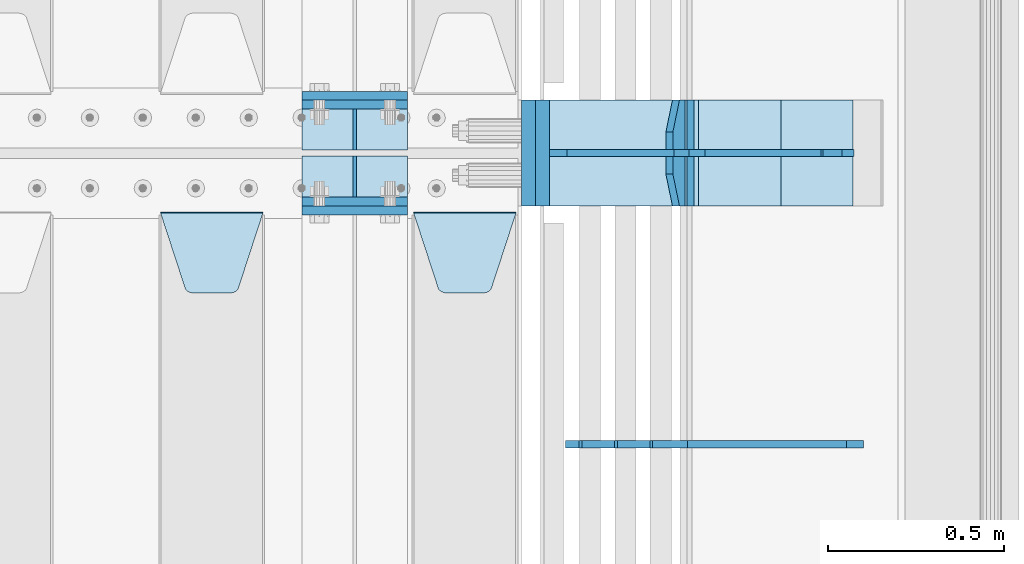
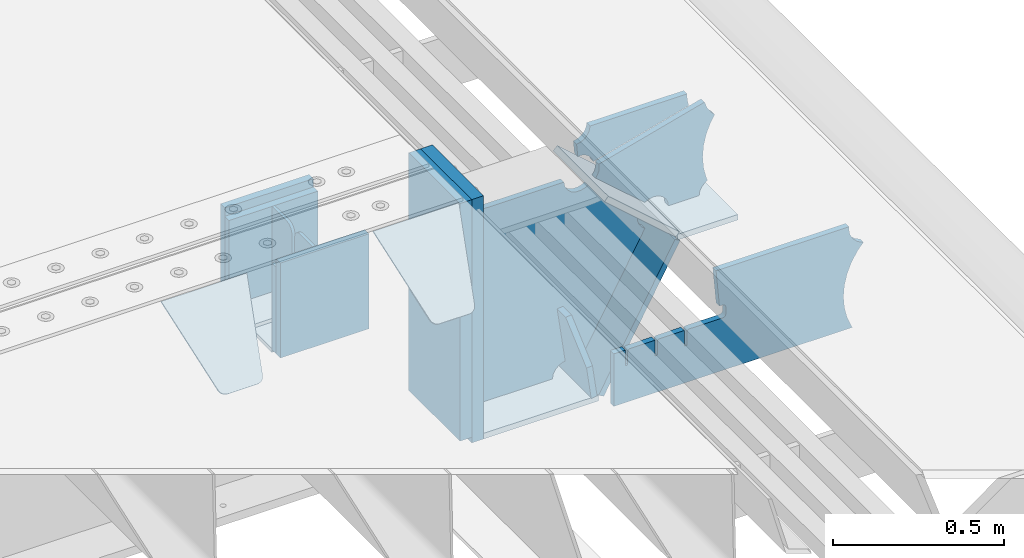
# One storey, part 208 of 240: 21 plates.
"""IFC2X3 building model written with IfcOpenShell, lengths in millimetres."""

from ifc_helpers import new_model, si_unit, frame, origin_with_axes, place, context, subcontext, project, spatial, faceted_brep, material, type_object, element, save


model = new_model("IFC2X3")

# Units and contexts
model_context = context("Model", 3, precision=1e-05, world=origin_with_axes())
body_context = subcontext(model_context, "Body", "Model", "MODEL_VIEW")
ifc_project = project(units=[si_unit("LENGTHUNIT", "METRE", prefix="MILLI"), si_unit("AREAUNIT", "SQUARE_METRE"), si_unit("VOLUMEUNIT", "CUBIC_METRE"), si_unit("MASSUNIT", "GRAM", prefix="KILO"), si_unit("TIMEUNIT", "SECOND"), si_unit("PLANEANGLEUNIT", "RADIAN"), si_unit("SOLIDANGLEUNIT", "STERADIAN"), si_unit("THERMODYNAMICTEMPERATUREUNIT", "DEGREE_CELSIUS"), si_unit("LUMINOUSINTENSITYUNIT", "LUMEN")], contexts=[model_context])

# Site, building, storey
site_placement = place(None, origin_with_axes())
site = spatial("IfcSite", under=ifc_project, at=site_placement, CompositionType="ELEMENT")
building_placement = place(site_placement, origin_with_axes())
building = spatial("IfcBuilding", under=site, at=building_placement, Name="Standard", CompositionType="ELEMENT")
storey_placement = place(building_placement, origin_with_axes())
storey = spatial("IfcBuildingStorey", under=building, at=storey_placement, Name="Undefined", CompositionType="ELEMENT", Elevation=0.0)

# Plates
ifc_material_1 = material(Name="STEEL/S355N")
plate_type_1 = type_object("IfcPlateType", PredefinedType="NOTDEFINED")
for number, where, z_axis, x_axis in (
    (1, (55855.0, 30137.5, -339.999999999995), (0.0, 0.0, 1.0), (1.0, 0.0, 0.0)),
    (2, (55855.0, 29862.5, -339.999999999995), (0.0, 0.0, 1.0), (1.0, 0.0, 0.0)),
):
    element("IfcPlate", number, at=place(storey_placement, frame(where, z_axis=z_axis, x_axis=x_axis)), inside=storey, type_object=plate_type_1, material=ifc_material_1, context=body_context, shape_type="Brep", body=[
        faceted_brep([(0.0, -12.5, 0.0), (0.0, -12.5, 310.0), (0.0, 12.5, 310.0), (0.0, 12.5, 0.0), (300.0, -12.5, 310.0), (300.0, 12.5, 310.0), (300.0, -12.5, 0.0), (300.0, 12.5, 0.0)], [[[0, 1, 2, 3]], [[1, 4, 5, 2]], [[4, 6, 7, 5]], [[6, 0, 3, 7]], [[5, 7, 3, 2]], [[6, 4, 1, 0]]]),
    ])
for number, where, z_axis, x_axis in (
    (3, (55855.0, 30162.5, -340.000000000044), (0.0, 0.0, 1.0), (1.0, 0.0, 0.0)),
    (4, (55855.0, 29837.5, -340.000000000044), (0.0, 0.0, 1.0), (1.0, 0.0, 0.0)),
):
    element("IfcPlate", number, at=place(storey_placement, frame(where, z_axis=z_axis, x_axis=x_axis)), inside=storey, type_object=plate_type_1, material=ifc_material_1, context=body_context, shape_type="Brep", body=[
        faceted_brep([(0.0, -12.5, 0.0), (9.31322574615479e-10, -12.5, 340.0), (9.31322574615479e-10, 12.5, 340.0), (0.0, 12.5, 0.0), (300.0, -12.5, 340.0), (300.0, 12.5, 340.0), (300.0, -12.5, 0.0), (300.0, 12.5, 0.0)], [[[0, 1, 2, 3]], [[1, 4, 5, 2]], [[4, 6, 7, 5]], [[6, 0, 3, 7]], [[5, 7, 3, 2]], [[6, 4, 1, 0]]]),
    ])
plate_type_2 = type_object("IfcPlateType", PredefinedType="NOTDEFINED")
for number, where, z_axis, x_axis in (
    (5, (55855.0, 30008.0, -342.999999999995), (0.0, 1.0, 0.0), (1.0, 0.0, 0.0)),
    (6, (55855.0, 29992.0, -342.999999999995), (0.0, -1.0, 0.0), (1.0, 0.0, 0.0)),
):
    element("IfcPlate", number, at=place(storey_placement, frame(where, z_axis=z_axis, x_axis=x_axis)), inside=storey, type_object=plate_type_2, material=ifc_material_1, context=body_context, shape_type="Brep", body=[
        faceted_brep([(0.0, -7.0, 0.0), (0.0, -7.0, 117.0), (0.0, 7.0, 117.0), (0.0, 7.0, 0.0), (300.0, -7.0, 117.0), (300.0, 7.0, 117.0), (300.0, -7.0, 0.0), (300.0, 7.0, 0.0)], [[[0, 1, 2, 3]], [[1, 4, 5, 2]], [[4, 6, 7, 5]], [[6, 0, 3, 7]], [[5, 7, 3, 2]], [[6, 4, 1, 0]]]),
    ])
plate_type_3 = type_object("IfcPlateType", PredefinedType="NOTDEFINED")
for number, where, z_axis, x_axis in (
    (7, (56005.0, 30008.0, -29.9999999999945), (0.0, 0.0, -1.0), (0.0, 1.0, 0.0)),
    (8, (56005.0, 29992.0, -29.9999999999945), (0.0, 0.0, -1.0), (0.0, -1.0, 0.0)),
):
    element("IfcPlate", number, at=place(storey_placement, frame(where, z_axis=z_axis, x_axis=x_axis)), inside=storey, type_object=plate_type_3, material=ifc_material_1, context=body_context, shape_type="Brep", body=[
        faceted_brep([(0.0, -5.0, 30.0), (0.0, -5.0, 306.0), (0.0, 5.0, 306.0), (0.0, 5.0, 30.0), (117.0, -5.0, 306.0), (117.0, 5.0, 306.0), (117.0, -5.0, 0.0), (117.0, 5.0, 0.0), (30.0, -5.0, 0.0), (30.0, 5.0, 0.0), (24.7905546699913, -5.0, 0.455767409633758), (24.7905546699913, 5.0, 0.455767409633758), (19.7393957002278, -5.0, 1.80922137642275), (19.7393957002278, 5.0, 1.80922137642275), (15.0, -5.0, 4.01923788646684), (15.0, 5.0, 4.01923788646684), (10.7163717094008, -5.0, 7.01866670643066), (10.7163717094008, 5.0, 7.01866670643066), (7.01866670643358, -5.0, 10.7163717094038), (7.01866670643358, 5.0, 10.7163717094038), (4.01923788646673, -5.0, 15.0), (4.01923788646673, 5.0, 15.0), (1.80922137642483, -5.0, 19.7393957002299), (1.80922137642483, 5.0, 19.7393957002299), (0.455767409635882, -5.0, 24.7905546699921), (0.455767409635882, 5.0, 24.7905546699921)], [[[0, 1, 2, 3]], [[1, 4, 5, 2]], [[4, 6, 7, 5]], [[6, 8, 9, 7]], [[8, 10, 11, 9]], [[10, 12, 13, 11]], [[12, 14, 15, 13]], [[14, 16, 17, 15]], [[16, 18, 19, 17]], [[18, 20, 21, 19]], [[20, 22, 23, 21]], [[22, 24, 25, 23]], [[24, 0, 3, 25]], [[5, 7, 9, 11, 13, 15, 17, 19, 21, 23, 25, 3, 2]], [[24, 22, 20, 18, 16, 14, 12, 10, 8, 6, 4, 1, 0]]]),
    ])
plate_type_4 = type_object("IfcPlateType", PredefinedType="NOTDEFINED")
plate_1_placement = place(storey_placement, frame((56172.0, 29831.767766956, -1.76776695296758), z_axis=(0.0, -0.707106781186547, -0.707106781186548), x_axis=(1.0, 0.0, 0.0)))
element("IfcPlate", 9, at=plate_1_placement, inside=storey, type_object=plate_type_4, material=ifc_material_1, context=body_context, shape_type="Brep", body=[
    faceted_brep([(0.0, -2.5, 0.0), (69.345504679477, -2.50000000000364, 300.171731424827), (69.345504679477, 2.49999999999636, 300.171731424827), (0.0, 2.5, 0.0), (70.927406119954, -2.50000000000364, 304.897442415397), (70.927406119954, 2.49999999999636, 304.897442415397), (73.3818627772271, -2.50000000000728, 309.234538108525), (73.3818627772271, 2.49999999999636, 309.234538108529), (76.6187032999587, -2.50000000000728, 313.023683126099), (76.6187032999587, 2.49999999999636, 313.023683126103), (80.5190132705029, -2.50000000000364, 316.125672595368), (80.5190132705029, 2.49999999999636, 316.125672595368), (84.9395038596849, -2.50000000000364, 318.426546230472), (84.9395038596849, 2.49999999999636, 318.426546230472), (89.7177759439219, -2.5, 319.841774983277), (89.7177759439219, 2.49999999999636, 319.841774983273), (94.6782862926484, -2.50000000000364, 320.319366455074), (94.6782862926484, 2.49999999999636, 320.319366455074), (195.321713707352, -2.50000000000364, 320.319366455074), (195.321713707352, 2.49999999999636, 320.319366455074), (200.282224056078, -2.50000000000364, 319.841774983273), (200.282224056078, 2.49999999999636, 319.841774983273), (205.060496140315, -2.50000000000364, 318.426546230472), (205.060496140315, 2.49999999999636, 318.426546230472), (209.480986729497, -2.50000000000364, 316.125672595368), (209.480986729497, 2.49999999999636, 316.125672595368), (213.381296700041, -2.50000000000728, 313.023683126099), (213.381296700041, 2.49999999999272, 313.023683126099), (216.618137222766, -2.50000000000364, 309.234538108522), (216.618137222766, 2.49999999999636, 309.234538108522), (219.072593880039, -2.50000000000364, 304.897442415397), (219.072593880039, 2.49999999999636, 304.897442415397), (220.654495320523, -2.50000000000364, 300.171731424827), (220.654495320523, 2.49999999999636, 300.171731424827), (290.0, -2.50000000000364, -3.63797880709171e-12), (290.0, 2.49999999999636, -3.63797880709171e-12)], [[[0, 1, 2, 3]], [[1, 4, 5, 2]], [[4, 6, 7, 5]], [[6, 8, 9, 7]], [[8, 10, 11, 9]], [[10, 12, 13, 11]], [[12, 14, 15, 13]], [[14, 16, 17, 15]], [[16, 18, 19, 17]], [[18, 20, 21, 19]], [[20, 22, 23, 21]], [[22, 24, 25, 23]], [[24, 26, 27, 25]], [[26, 28, 29, 27]], [[28, 30, 31, 29]], [[30, 32, 33, 31]], [[32, 34, 35, 33]], [[34, 0, 3, 35]], [[5, 7, 9, 11, 13, 15, 17, 19, 21, 23, 25, 27, 29, 31, 33, 35, 3, 2]], [[34, 32, 30, 28, 26, 24, 22, 20, 18, 16, 14, 12, 10, 8, 6, 4, 1, 0]]]),
])
plate_2_placement = place(storey_placement, frame((55455.0, 29831.767766956, -1.76776695296758), z_axis=(0.0, -0.707106781186547, -0.707106781186548), x_axis=(1.0, 0.0, 0.0)))
element("IfcPlate", 10, at=plate_2_placement, inside=storey, type_object=plate_type_4, material=ifc_material_1, context=body_context, shape_type="Brep", body=[
    faceted_brep([(0.0, -2.5, 0.0), (69.345504679477, -2.50000000000364, 300.171731424827), (69.345504679477, 2.49999999999636, 300.171731424827), (0.0, 2.5, 0.0), (70.927406119954, -2.50000000000364, 304.897442415397), (70.927406119954, 2.49999999999636, 304.897442415397), (73.3818627772271, -2.50000000000728, 309.234538108525), (73.3818627772271, 2.49999999999636, 309.234538108529), (76.6187032999587, -2.50000000000728, 313.023683126099), (76.6187032999587, 2.49999999999636, 313.023683126103), (80.5190132705029, -2.50000000000364, 316.125672595368), (80.5190132705029, 2.49999999999636, 316.125672595368), (84.9395038596849, -2.50000000000364, 318.426546230472), (84.9395038596849, 2.49999999999636, 318.426546230472), (89.7177759439219, -2.5, 319.841774983277), (89.7177759439219, 2.49999999999636, 319.841774983273), (94.6782862926484, -2.50000000000364, 320.319366455074), (94.6782862926484, 2.49999999999636, 320.319366455074), (195.321713707352, -2.50000000000364, 320.319366455074), (195.321713707352, 2.49999999999636, 320.319366455074), (200.282224056078, -2.50000000000364, 319.841774983273), (200.282224056078, 2.49999999999636, 319.841774983273), (205.060496140315, -2.50000000000364, 318.426546230472), (205.060496140315, 2.49999999999636, 318.426546230472), (209.480986729497, -2.50000000000364, 316.125672595368), (209.480986729497, 2.49999999999636, 316.125672595368), (213.381296700041, -2.50000000000728, 313.023683126099), (213.381296700041, 2.49999999999272, 313.023683126099), (216.618137222766, -2.50000000000364, 309.234538108522), (216.618137222766, 2.49999999999636, 309.234538108522), (219.072593880039, -2.50000000000364, 304.897442415397), (219.072593880039, 2.49999999999636, 304.897442415397), (220.654495320523, -2.50000000000364, 300.171731424827), (220.654495320523, 2.49999999999636, 300.171731424827), (290.0, -2.50000000000364, -3.63797880709171e-12), (290.0, 2.49999999999636, -3.63797880709171e-12)], [[[0, 1, 2, 3]], [[1, 4, 5, 2]], [[4, 6, 7, 5]], [[6, 8, 9, 7]], [[8, 10, 11, 9]], [[10, 12, 13, 11]], [[12, 14, 15, 13]], [[14, 16, 17, 15]], [[16, 18, 19, 17]], [[18, 20, 21, 19]], [[20, 22, 23, 21]], [[22, 24, 25, 23]], [[24, 26, 27, 25]], [[26, 28, 29, 27]], [[28, 30, 31, 29]], [[30, 32, 33, 31]], [[32, 34, 35, 33]], [[34, 0, 3, 35]], [[5, 7, 9, 11, 13, 15, 17, 19, 21, 23, 25, 27, 29, 31, 33, 35, 3, 2]], [[34, 32, 30, 28, 26, 24, 22, 20, 18, 16, 14, 12, 10, 8, 6, 4, 1, 0]]]),
])
plate_type_5 = type_object("IfcPlateType", PredefinedType="NOTDEFINED")
plate_3_placement = place(storey_placement, frame((56931.0775331947, 30150.0000000017, -871.412303810021), z_axis=(0.0, -1.0, 0.0), x_axis=(-0.137902988002476, 0.0, 0.990445741017643)))
element("IfcPlate", 11, at=plate_3_placement, inside=storey, type_object=plate_type_5, material=ifc_material_1, context=body_context, shape_type="Brep", body=[
    faceted_brep([(0.0, -10.0, 0.0), (-1.98269844986498e-10, -10.0, 300.0), (-1.98269844986498e-10, 10.0, 300.0), (0.0, 10.0, 0.0), (115.0, -10.0, 300.0), (115.0, 10.0, 300.0), (250.0, -10.0, 210.0), (250.0, 10.0, 210.0), (250.0, -10.0, 90.0), (250.0, 10.0, 90.0), (115.0, -10.0, -1.09139364212751e-10), (115.0, 10.0, -1.09139364212751e-10)], [[[0, 1, 2, 3]], [[1, 4, 5, 2]], [[4, 6, 7, 5]], [[6, 8, 9, 7]], [[8, 10, 11, 9]], [[10, 0, 3, 11]], [[5, 7, 9, 11, 3, 2]], [[10, 8, 6, 4, 1, 0]]]),
])
plate_type_6 = type_object("IfcPlateType", PredefinedType="NOTDEFINED")
plate_4_placement = place(storey_placement, frame((56959.9988298914, 30000.0000000001, -179.999999999866), z_axis=(0.0, 0.0, -1.0), x_axis=(-1.0, 0.0, 0.0)))
element("IfcPlate", 12, at=plate_4_placement, inside=storey, type_object=plate_type_6, material=ifc_material_1, context=body_context, shape_type="Brep", body=[
    faceted_brep([(46.0258547361809, 10.0, 641.078828352491), (73.3015011075258, 10.0000000000146, 445.179898435806), (73.3015011075258, -9.99999999998545, 445.179898435806), (46.0258547361809, -10.0, 641.078828352491), (53.4925862871751, 10.0000000000146, 442.421838675757), (53.4925862871751, -9.99999999998545, 442.421838675757), (25.782050112437, 10.0, 641.444230671302), (25.782050112437, -10.0, 641.444230671302), (54.6652503111691, 10.0, 642.447174185377), (54.6652503111691, -10.0, 642.447174185377), (68.6036632070463, -10.0, 649.549150281387), (68.6036632070463, 10.0, 649.549150281387), (79.6652503111691, -10.0, 660.610737385511), (79.6652503111691, 10.0, 660.610737385511), (86.7672264071807, -10.0, 674.549150281387), (86.7672264071807, 10.0, 674.549150281387), (89.2144005924201, -10.0, 690.0), (89.2144005924201, 10.0, 690.0), (353.0, -10.0, 690.0), (353.0, 10.0, 690.0), (355.447174185239, -10.0, 674.549150281253), (355.447174185239, 10.0, 674.549150281253), (362.549150281251, -10.0, 660.610737385376), (362.549150281251, 10.0, 660.610737385376), (373.610737385374, -10.0, 649.549150281253), (373.610737385374, 10.0, 649.549150281253), (387.549150281251, -10.0, 642.447174185242), (387.549150281251, 10.0, 642.447174185242), (403.0, -10.0, 640.0), (403.0, 10.0, 640.0), (403.0, -10.0, 50.0), (403.0, 10.0, 50.0), (387.549150281251, -10.0, 47.5528258147577), (387.549150281251, 10.0, 47.5528258147577), (373.610737385374, -10.0, 40.4508497187474), (373.610737385374, 10.0, 40.4508497187474), (362.549150281251, -10.0, 29.3892626146236), (362.549150281251, 10.0, 29.3892626146236), (355.447174185239, -10.0, 15.4508497187474), (355.447174185239, 10.0, 15.4508497187474), (353.0, -10.0, 0.0), (353.0, 10.0, 0.0), (50.0, -10.0, 0.0), (50.0, 10.0, 0.0), (47.0349915316328, -10.0, 16.9620037619133), (47.0349915316328, 10.0, 16.9620037619133), (38.4916171352306, -10.0, 31.9123081320451), (38.4916171352306, 10.0, 31.9123081320451), (25.3831239081483, -10.0, 43.0778019479116), (25.3831239081483, 10.0, 43.0778019479116), (9.26418358741648, -10.0, 49.1342538608113), (9.26418358741648, 10.0, 49.1342538608113), (-7.95349204488593, -10.0, 49.363366622344), (-7.95349204488593, 10.0, 49.363366622344), (-24.2278808265401, -10.0, 43.7379673813837), (-24.2278808265401, 10.0, 43.7379673813837), (-37.6288347353475, -10.0, 32.9252303934259), (-37.6288347353475, 10.0, 32.9252303934259), (-210.371165264653, -10.0, 184.074769606574), (-210.371165264653, 10.0, 184.074769606574), (-202.382363280565, -10.0, 196.529747922069), (-202.382363280565, 10.0, 196.529747922069), (-198.388707244048, -10.0, 210.777489969227), (-198.388707244048, 10.0, 210.777489969227), (-198.73995746443, -10.0, 225.570193077959), (-198.73995746443, 10.0, 225.570193077959), (-203.40535180681, -10.0, 239.612327446012), (-203.40535180681, 10.0, 239.612327446012), (-211.976299808361, -10.0, 251.674097313455), (-211.976299808361, 10.0, 251.674097313455), (-223.702166612966, -10.0, 260.699145216992), (-223.702166612966, 10.0, 260.699145216992), (-9.29783338703419, -10.0, 646.300854783008), (-9.29783338703419, 10.0, 646.300854783008), (6.98069453598146, -10.0, 640.647282345602), (6.98069453598146, 10.0, 640.647282345602), (24.2117663163663, -10.0, 640.855891896051), (24.2117663163663, 10.0, 640.855891896051)], [[[0, 1, 2, 3]], [[4, 5, 2, 1]], [[6, 7, 5, 4]], [[8, 9, 10, 11]], [[11, 10, 12, 13]], [[13, 12, 14, 15]], [[15, 14, 16, 17]], [[18, 19, 17, 16]], [[18, 20, 21, 19]], [[20, 22, 23, 21]], [[22, 24, 25, 23]], [[24, 26, 27, 25]], [[26, 28, 29, 27]], [[28, 30, 31, 29]], [[30, 32, 33, 31]], [[32, 34, 35, 33]], [[34, 36, 37, 35]], [[36, 38, 39, 37]], [[38, 40, 41, 39]], [[40, 42, 43, 41]], [[42, 44, 45, 43]], [[44, 46, 47, 45]], [[46, 48, 49, 47]], [[48, 50, 51, 49]], [[50, 52, 53, 51]], [[52, 54, 55, 53]], [[54, 56, 57, 55]], [[56, 58, 59, 57]], [[58, 60, 61, 59]], [[60, 62, 63, 61]], [[62, 64, 65, 63]], [[64, 66, 67, 65]], [[66, 68, 69, 67]], [[68, 70, 71, 69]], [[70, 72, 73, 71]], [[72, 74, 75, 73]], [[74, 76, 77, 75]], [[1, 0, 8, 11, 13, 15, 17, 19, 21, 23, 25, 27, 29, 31, 33, 35, 37, 39, 41, 43, 45, 47, 49, 51, 53, 55, 57, 59, 61, 63, 65, 67, 69, 71, 73, 75, 77, 6, 4]], [[9, 8, 0, 3]], [[76, 74, 72, 70, 68, 66, 64, 62, 60, 58, 56, 54, 52, 50, 48, 46, 44, 42, 40, 38, 36, 34, 32, 30, 28, 26, 24, 22, 20, 18, 16, 14, 12, 10, 9, 3, 2, 5, 7]], [[77, 76, 7, 6]]]),
])
plate_type_7 = type_object("IfcPlateType", PredefinedType="NOTDEFINED")
plate_5_placement = place(storey_placement, frame((57500.9988502513, 29999.9999999993, -28.9999913318487), z_axis=(0.260769276985653, 0.0, -0.965401151946889), x_axis=(-0.965401151946889, 0.0, -0.260769276985654)))
element("IfcPlate", 13, at=plate_5_placement, inside=storey, type_object=plate_type_7, material=ifc_material_1, context=body_context, shape_type="Brep", body=[
    faceted_brep([(183.436474692309, 10.0, 275.852500330424), (184.91838860904, 10.0, 264.41784353133), (184.91838860904, -10.0, 264.41784353133), (183.436474692309, -10.0, 275.852500330424), (183.794583267605, 10.0, 224.576469334612), (183.794583267605, -10.0, 224.576469334612), (176.45204977582, 10.0, 185.401410454628), (176.45204977582, -10.0, 185.401410454628), (163.071585676764, 10.0, 147.857286855562), (163.071585676764, -10.0, 147.857286855562), (143.982662403731, 10.0, 112.868559462233), (143.982662403731, -10.0, 112.868559462233), (119.655312600233, 10.0, 81.2967668639885), (119.655312600233, -10.0, 81.2967668639885), (100.960891712748, 10.0, 63.6280409830943), (100.960891712748, -10.0, 63.6280409830943), (194.486836975891, -10.0, 278.751956446691), (207.178624553366, -10.0, 286.650994937518), (207.178624553366, 10.0, 286.650994937518), (194.486836975891, 10.0, 278.751956446691), (216.968013469435, -10.0, 297.948965801399), (216.968013469435, 10.0, 297.948965801399), (222.979925232852, -10.0, 311.635937633771), (222.979925232852, 10.0, 311.635937633771), (323.381647032758, -10.0, 284.515917834986), (323.381647032758, 10.0, 284.515917834986), (321.720617177329, -10.0, 268.853198956864), (321.720617177329, 10.0, 268.853198956864), (325.014344481133, -10.0, 253.450889283185), (325.014344481133, 10.0, 253.450889283185), (332.935986082477, -10.0, 239.837389469556), (332.935986082477, 10.0, 239.837389469556), (344.699462330085, -10.0, 229.363593146938), (344.699462330085, 10.0, 229.363593146938), (359.1374609708, -10.0, 223.068835162203), (359.1374609708, 10.0, 223.068835162203), (374.817271777676, -10.0, 221.577756392893), (374.817271777676, 10.0, 221.577756392893), (390.182952880852, -10.0, 225.03833007813), (390.182952880852, 10.0, 225.03833007813), (512.909060513019, -10.0, 41.5599003357038), (512.909060513019, 10.0, 41.5599003357038), (503.648024844573, -10.0, 33.564366674771), (503.648024844573, 10.0, 33.564366674771), (496.6060645697, -10.0, 23.5590612990018), (496.6060645697, 10.0, 23.5590612990018), (492.204839143924, -10.0, 12.1430832451115), (492.204839143924, 10.0, 12.1430832451115), (490.707885742188, -10.0, 3.8198777474463e-10), (490.707885742188, 10.0, 3.8198777474463e-10), (119.999999999993, -10.0, 9.64064383879304e-11), (119.999999999993, 10.0, 9.64064383879304e-11), (117.226254779103, -10.0, 25.6516118492182), (117.226254779103, 10.0, 25.6516118492182), (109.033246825653, -10.0, 50.1173731021008), (109.033246825653, 10.0, 50.1173731021008)], [[[0, 1, 2, 3]], [[4, 5, 2, 1]], [[6, 7, 5, 4]], [[8, 9, 7, 6]], [[10, 11, 9, 8]], [[12, 13, 11, 10]], [[14, 15, 13, 12]], [[16, 17, 18, 19]], [[17, 20, 21, 18]], [[20, 22, 23, 21]], [[22, 24, 25, 23]], [[24, 26, 27, 25]], [[26, 28, 29, 27]], [[28, 30, 31, 29]], [[30, 32, 33, 31]], [[32, 34, 35, 33]], [[34, 36, 37, 35]], [[36, 38, 39, 37]], [[38, 40, 41, 39]], [[40, 42, 43, 41]], [[42, 44, 45, 43]], [[44, 46, 47, 45]], [[46, 48, 49, 47]], [[48, 50, 51, 49]], [[50, 52, 53, 51]], [[52, 54, 55, 53]], [[10, 8, 6, 4, 1, 0, 19, 18, 21, 23, 25, 27, 29, 31, 33, 35, 37, 39, 41, 43, 45, 47, 49, 51, 53, 55, 14, 12]], [[16, 19, 0, 3]], [[54, 52, 50, 48, 46, 44, 42, 40, 38, 36, 34, 32, 30, 28, 26, 24, 22, 20, 17, 16, 3, 2, 5, 7, 9, 11, 13, 15]], [[55, 54, 15, 14]]]),
])
plate_type_8 = type_object("IfcPlateType", PredefinedType="NOTDEFINED")
plate_6_placement = place(storey_placement, frame((56972.2260590443, 30149.9999999993, -177.219372761326), z_axis=(0.752414935148685, 0.0, -0.658689430130164), x_axis=(0.0, -1.0, 0.0)))
element("IfcPlate", 14, at=plate_6_placement, inside=storey, type_object=plate_type_8, material=ifc_material_1, context=body_context, shape_type="Brep", body=[
    faceted_brep([(0.0, -10.0, 0.0), (1.09139364212751e-10, -10.0000000000073, 319.999999999993), (1.09139364212751e-10, 10.0, 319.999999999993), (0.0, 10.0, 0.0), (300.0, -10.0000000000073, 319.999999999993), (300.0, 10.0, 319.999999999993), (300.0, -10.0, 5.82076609134674e-11), (300.0, 10.0, 5.82076609134674e-11)], [[[0, 1, 2, 3]], [[1, 4, 5, 2]], [[4, 6, 7, 5]], [[6, 0, 3, 7]], [[5, 7, 3, 2]], [[6, 4, 1, 0]]]),
])
plate_7_placement = place(storey_placement, frame((57213.0007288109, 30150.0000000001, -408.004820491625), z_axis=(-0.484064236150485, 0.0, -0.875032465272031), x_axis=(0.0, -1.0, 0.0)))
element("IfcPlate", 15, at=plate_7_placement, inside=storey, type_object=plate_type_8, material=ifc_material_1, context=body_context, shape_type="Brep", body=[
    faceted_brep([(0.0, -10.0, 0.0), (3.86513420380652e-07, -10.0, 533.528442382813), (3.86513420380652e-07, 9.99999999999272, 533.528442382809), (0.0, 10.0, 0.0), (300.003295898438, -10.0000000000073, 533.549133300778), (300.003295898438, 10.0, 533.549133300781), (300.0, -10.0, 5.82076609134674e-11), (300.0, 10.0, 5.82076609134674e-11)], [[[0, 1, 2, 3]], [[1, 4, 5, 2]], [[4, 6, 7, 5]], [[6, 0, 3, 7]], [[5, 7, 3, 2]], [[6, 4, 1, 0]]]),
])
plate_8_placement = place(storey_placement, frame((56556.9988298914, 30150.0000000001, -879.999999999866), z_axis=(0.0, -1.0, 0.0), x_axis=(1.0, 0.0, 0.0)))
element("IfcPlate", 16, at=plate_8_placement, inside=storey, type_object=plate_type_8, material=ifc_material_1, context=body_context, shape_type="Brep", body=[
    faceted_brep([(0.0, -10.0, 0.0), (-1.98269844986498e-10, -10.0, 300.0), (-1.98269844986498e-10, 10.0, 300.0), (0.0, 10.0, 0.0), (389.0, -10.0, 300.0), (389.0, 10.0, 300.0), (389.0, -10.0, 0.0), (389.0, 10.0, 0.0)], [[[0, 1, 2, 3]], [[1, 4, 5, 2]], [[4, 6, 7, 5]], [[6, 0, 3, 7]], [[5, 7, 3, 2]], [[6, 4, 1, 0]]]),
])
plate_type_9 = type_object("IfcPlateType", PredefinedType="NOTDEFINED")
plate_9_placement = place(storey_placement, frame((57416.9988298914, 30149.9999999993, -397.999999999763), z_axis=(-1.0, 0.0, 0.0), x_axis=(0.0, -1.0, 0.0)))
element("IfcPlate", 17, at=plate_9_placement, inside=storey, type_object=plate_type_9, material=ifc_material_1, context=body_context, shape_type="Brep", body=[
    faceted_brep([(0.0, -10.0, 0.0), (4.65661287307739e-10, -10.0, 204.0), (4.65661287307739e-10, 10.0, 204.0), (0.0, 10.0, 0.0), (300.0, -10.0, 204.0), (300.0, 10.0, 204.0), (300.0, -10.0, 5.82076609134674e-11), (300.0, 10.0, 5.82076609134674e-11)], [[[0, 1, 2, 3]], [[1, 4, 5, 2]], [[4, 6, 7, 5]], [[6, 0, 3, 7]], [[5, 7, 3, 2]], [[6, 4, 1, 0]]]),
])
ifc_material_2 = material()
plate_type_10 = type_object("IfcPlateType", PredefinedType="NOTDEFINED")
plate_10_placement = place(storey_placement, frame((56536.9988298907, 30150.0, -889.999999999995), z_axis=(0.0, 0.0, 1.0), x_axis=(0.0, -1.0, 0.0)))
element("IfcPlate", 18, at=plate_10_placement, inside=storey, type_object=plate_type_10, material=ifc_material_2, context=body_context, shape_type="Brep", body=[
    faceted_brep([(0.0, -20.0, 0.0), (0.0, -20.0, 870.0), (0.0, 20.0, 870.0), (0.0, 20.0, 0.0), (300.0, -20.0, 870.0), (300.0, 20.0, 870.0), (300.0, -20.0, -1.81898940354586e-12), (300.0, 20.0, -1.81898940354586e-12)], [[[0, 1, 2, 3]], [[1, 4, 5, 2]], [[4, 6, 7, 5]], [[6, 0, 3, 7]], [[5, 7, 3, 2]], [[6, 4, 1, 0]]]),
])
plate_11_placement = place(storey_placement, frame((56497.0, 30150.0, -870.0), z_axis=(0.0, 0.0, 1.0), x_axis=(0.0, -1.0, 0.0)))
element("IfcPlate", 19, at=plate_11_placement, inside=storey, type_object=plate_type_10, material=ifc_material_2, context=body_context, shape_type="Brep", body=[
    faceted_brep([(0.0, -20.0, 0.0), (0.0, -20.0, 850.0), (0.0, 20.0, 850.0), (0.0, 20.0, 0.0), (300.0, -20.0, 850.0), (300.0, 20.0, 850.0), (300.0, -20.0, -1.81898940354586e-12), (300.0, 20.0, -1.81898940354586e-12)], [[[0, 1, 2, 3]], [[1, 4, 5, 2]], [[4, 6, 7, 5]], [[6, 0, 3, 7]], [[5, 7, 3, 2]], [[6, 4, 1, 0]]]),
])
plate_type_11 = type_object("IfcPlateType", PredefinedType="NOTDEFINED")
plate_12_placement = place(storey_placement, frame((57495.9988298907, 30000.0, -9.99999999999716), z_axis=(0.0, 0.0, -1.0), x_axis=(-1.0, 0.0, 0.0)))
element("IfcPlate", 20, at=plate_12_placement, inside=storey, type_object=plate_type_11, material=ifc_material_1, context=body_context, shape_type="Brep", body=[
    faceted_brep([(164.157641141064, -10.0, 44.1844865875018), (486.71834084086, -10.0, 131.004562768382), (486.71834084086, 10.0, 131.004562768382), (164.157641141064, 10.0, 44.1844865875018), (492.179177700767, -10.0, 118.185717565315), (492.179177700767, 10.0, 118.185717565315), (500.965368826706, -10.0, 107.371542744776), (500.965368826706, 10.0, 107.371542744776), (512.394601349042, -10.0, 99.4018391429503), (512.394601349042, 10.0, 99.4018391429503), (525.579310641864, -10.0, 94.8955133209048), (525.579310641864, 10.0, 94.8955133209048), (539.495606295335, -10.0, 94.2025148824028), (539.495606295335, 10.0, 94.2025148824028), (543.504393704665, -10.0, 49.7974851175972), (543.504393704665, 10.0, 49.7974851175972), (529.167086307512, -10.0, 46.3176139481669), (529.167086307512, 10.0, 46.3176139481669), (516.469507120331, -10.0, 38.8049999196639), (516.469507120331, 10.0, 38.8049999196639), (506.517198234542, -10.0, 27.9137449599276), (506.517198234542, 10.0, 27.9137449599276), (500.17667886756, -10.0, 14.592119649441), (500.17667886756, 10.0, 14.592119649441), (498.0, -10.0, 0.0), (498.0, 10.0, 0.0), (170.0, -10.0, 0.0), (170.0, 10.0, 0.0), (169.632873911985, -10.0, 11.1663820622718), (169.632873911985, 10.0, 11.1663820622718), (168.533081313406, -10.0, 22.2845350637931), (168.533081313406, 10.0, 22.2845350637931), (166.705372351957, -10.0, 33.3064382514178), (166.705372351957, 10.0, 33.3064382514178)], [[[0, 1, 2, 3]], [[1, 4, 5, 2]], [[4, 6, 7, 5]], [[6, 8, 9, 7]], [[8, 10, 11, 9]], [[10, 12, 13, 11]], [[12, 14, 15, 13]], [[14, 16, 17, 15]], [[16, 18, 19, 17]], [[18, 20, 21, 19]], [[20, 22, 23, 21]], [[22, 24, 25, 23]], [[24, 26, 27, 25]], [[26, 28, 29, 27]], [[28, 30, 31, 29]], [[30, 32, 33, 31]], [[32, 0, 3, 33]], [[5, 7, 9, 11, 13, 15, 17, 19, 21, 23, 25, 27, 29, 31, 33, 3, 2]], [[32, 30, 28, 26, 24, 22, 20, 18, 16, 14, 12, 10, 8, 6, 4, 1, 0]]]),
])
plate_type_12 = type_object("IfcPlateType", PredefinedType="NOTDEFINED")
plate_13_placement = place(storey_placement, frame((57442.9182339676, 29174.9992828369, -374.002067436517), z_axis=(0.0, 0.0, 1.0), x_axis=(-1.0, 0.0, 0.0)))
element("IfcPlate", 21, at=plate_13_placement, inside=storey, type_object=plate_type_12, material=ifc_material_1, context=body_context, shape_type="Brep", body=[
    faceted_brep([(801.919404066546, -10.0, 188.0), (801.919404066546, 10.0, 188.0), (801.919404066546, 10.0, 132.002067436952), (801.919404066546, -10.0, 132.002067436952), (793.919404066546, 10.0, 132.002067436952), (793.919404066546, -10.0, 132.002067436952), (793.919404066546, 10.0, 180.002067436952), (793.919404066546, -10.0, 180.002067436952), (793.52785619691, 10.0, 182.474203391951), (793.52785619691, -10.0, 182.474203391951), (792.391540021548, 10.0, 184.704349455291), (792.391540021548, -10.0, 184.704349455291), (790.621686084887, 10.0, 186.474203391951), (790.621686084887, -10.0, 186.474203391951), (788.391540021548, 10.0, 187.610519567313), (788.391540021548, -10.0, 187.610519567313), (785.919404066546, -10.0, 188.002067436952), (785.919404066546, 10.0, 188.0), (841.0, -10.0, 188.0), (841.0, -10.0, 0.0), (841.0, 10.0, 0.0), (841.0, 10.0, 188.0), (33.3619566735943, -10.0, 0.0), (33.3619566735943, 10.0, 0.0), (36.2350612208102, -10.0, 4.68848050267013), (36.2350612208102, 10.0, 4.68848050267013), (51.4877592159319, -10.0, 41.5117508652784), (51.4877592159319, 10.0, 41.5117508652784), (60.7922425881334, -10.0, 80.2677133162964), (60.7922425881334, 10.0, 80.2677133162964), (63.9194040769653, -10.0, 120.002067436515), (63.9194040769653, 10.0, 120.002067436515), (60.7922425881334, -10.0, 159.736421556734), (60.7922425881334, 10.0, 159.736421556734), (51.4877592159319, -10.0, 198.492384007752), (51.4877592159319, 10.0, 198.492384007752), (36.2350612208102, -10.0, 235.31565437036), (36.2350612208102, 10.0, 235.31565437036), (15.4097206482038, -10.0, 269.299521518803), (15.4097206482038, 10.0, 269.299521518803), (-3.35474438100209, -10.0, 291.269887256574), (-3.35474438100209, 10.0, 291.269887256574), (-2.36881039375294, -10.0000000000036, 291.426043859339), (-2.36881039375294, 10.0, 291.426043859339), (17.1449676604752, -10.0000000000036, 301.368810393754), (17.1449676604752, 10.0, 301.368810393754), (32.6311896062471, -10.0000000000036, 316.855032339527), (32.6311896062471, 10.0, 316.855032339527), (42.573956140659, -10.0000000000036, 336.368810393754), (42.573956140659, 10.0, 336.368810393754), (46.0, -10.0000000000036, 358.0), (46.0, 10.0, 358.0), (45.0495205499246, -10.0, 364.001091067617), (45.0495205499246, 10.0, 364.001091067617), (495.040008544922, -10.0, 364.010009765625), (495.040008544922, 10.0, 364.010009765625), (483.600036621094, -10.0, 233.759994506836), (483.600036621094, 10.0, 233.759994506836), (472.0, -10.0, 233.759994506836), (472.0, 10.0, 233.759994506836), (468.909830056247, -10.0, 233.270559669787), (468.909830056247, 10.0, 233.270559669787), (466.122147477072, -10.0, 231.850164450585), (466.122147477072, 10.0, 231.850164450585), (463.909830056247, -10.0, 229.637847029761), (463.909830056247, 10.0, 229.637847029761), (462.489434837051, -10.0, 226.850164450585), (462.489434837051, 10.0, 226.850164450585), (462.0, -10.0, 223.759994506836), (462.0, 10.0, 223.759994506836), (462.0, -10.0, 198.0), (462.0, 10.0, 198.0), (462.489434837051, -10.0, 194.909830056251), (462.489434837051, 10.0, 194.909830056251), (463.909830056247, -10.0, 192.122147477075), (463.909830056247, 10.0, 192.122147477075), (466.122147477072, -10.0, 189.909830056251), (466.122147477072, 10.0, 189.909830056251), (468.909830056247, -10.0, 188.489434837048), (468.909830056247, 10.0, 188.489434837048), (472.0, -10.0, 188.0), (472.0, 10.0, 188.0), (585.919404066546, -10.0, 188.002067436952), (585.919404066546, 10.0, 188.0), (588.391540021548, -9.99999999999636, 187.610519567313), (588.391540021548, 10.0, 187.610519567313), (590.621686084887, -9.99999999999636, 186.474203391951), (590.621686084887, 10.0, 186.474203391951), (592.391540021548, -9.99999999999636, 184.704349455291), (592.391540021548, 10.0, 184.704349455291), (593.52785619691, -9.99999999999636, 182.474203391951), (593.52785619691, 10.0, 182.474203391951), (593.919404066546, -9.99999999999636, 180.002067436952), (593.919404066546, 10.0, 180.002067436952), (593.919404066546, -9.99999999999636, 132.002067436952), (593.919404066546, 10.0, 132.002067436952), (601.919404066546, -9.99999999999636, 132.002067436952), (601.919404066546, 10.0, 132.002067436952), (601.919404066546, -10.0, 188.0), (601.919404066546, 10.0, 188.0), (685.919404066546, -10.0, 188.002067436952), (685.919404066546, 10.0, 188.0), (688.391540021548, -10.0, 187.610519567313), (688.391540021548, 10.0, 187.610519567313), (690.621686084887, -10.0, 186.474203391951), (690.621686084887, 10.0, 186.474203391951), (692.391540021548, -10.0, 184.704349455291), (692.391540021548, 10.0, 184.704349455291), (693.52785619691, -10.0, 182.474203391951), (693.52785619691, 10.0, 182.474203391951), (693.919404066546, -10.0, 180.002067436952), (693.919404066546, 10.0, 180.002067436952), (693.919404066546, -10.0, 132.002067436952), (693.919404066546, 10.0000000000036, 132.002067436952), (701.919404066546, -10.0, 132.002067436952), (701.919404066546, 10.0000000000036, 132.002067436952), (701.919404066546, -10.0, 188.0), (701.919404066546, 10.0, 188.0)], [[[0, 1, 2, 3]], [[3, 2, 4, 5]], [[5, 4, 6, 7]], [[7, 6, 8, 9]], [[9, 8, 10, 11]], [[11, 10, 12, 13]], [[13, 12, 14, 15]], [[16, 15, 14, 17]], [[18, 19, 20, 21]], [[20, 19, 22, 23]], [[22, 24, 25, 23]], [[26, 27, 25, 24]], [[28, 29, 27, 26]], [[30, 31, 29, 28]], [[32, 33, 31, 30]], [[34, 35, 33, 32]], [[36, 37, 35, 34]], [[38, 39, 37, 36]], [[39, 38, 40, 41]], [[40, 42, 43, 41]], [[44, 45, 43, 42]], [[46, 47, 45, 44]], [[48, 49, 47, 46]], [[50, 51, 49, 48]], [[52, 53, 51, 50]], [[54, 55, 53, 52]], [[54, 56, 57, 55]], [[56, 58, 59, 57]], [[58, 60, 61, 59]], [[60, 62, 63, 61]], [[62, 64, 65, 63]], [[64, 66, 67, 65]], [[66, 68, 69, 67]], [[68, 70, 71, 69]], [[70, 72, 73, 71]], [[72, 74, 75, 73]], [[74, 76, 77, 75]], [[76, 78, 79, 77]], [[78, 80, 81, 79]], [[81, 80, 82, 83]], [[82, 84, 85, 83]], [[86, 87, 85, 84]], [[88, 89, 87, 86]], [[90, 91, 89, 88]], [[92, 93, 91, 90]], [[94, 95, 93, 92]], [[96, 97, 95, 94]], [[98, 99, 97, 96]], [[99, 98, 100, 101]], [[100, 102, 103, 101]], [[104, 105, 103, 102]], [[106, 107, 105, 104]], [[108, 109, 107, 106]], [[110, 111, 109, 108]], [[112, 113, 111, 110]], [[114, 115, 113, 112]], [[116, 117, 115, 114]], [[117, 116, 16, 17]], [[12, 10, 8, 6, 4, 2, 1, 21, 20, 23, 25, 27, 29, 31, 33, 35, 37, 39, 41, 43, 45, 47, 49, 51, 53, 55, 57, 59, 61, 63, 65, 67, 69, 71, 73, 75, 77, 79, 81, 83, 85, 87, 89, 91, 93, 95, 97, 99, 101, 103, 105, 107, 109, 111, 113, 115, 117, 17, 14]], [[18, 21, 1, 0]], [[116, 114, 112, 110, 108, 106, 104, 102, 100, 98, 96, 94, 92, 90, 88, 86, 84, 82, 80, 78, 76, 74, 72, 70, 68, 66, 64, 62, 60, 58, 56, 54, 52, 50, 48, 46, 44, 42, 40, 38, 36, 34, 32, 30, 28, 26, 24, 22, 19, 18, 0, 3, 5, 7, 9, 11, 13, 15, 16]]]),
])

save(model, "model.ifc")
